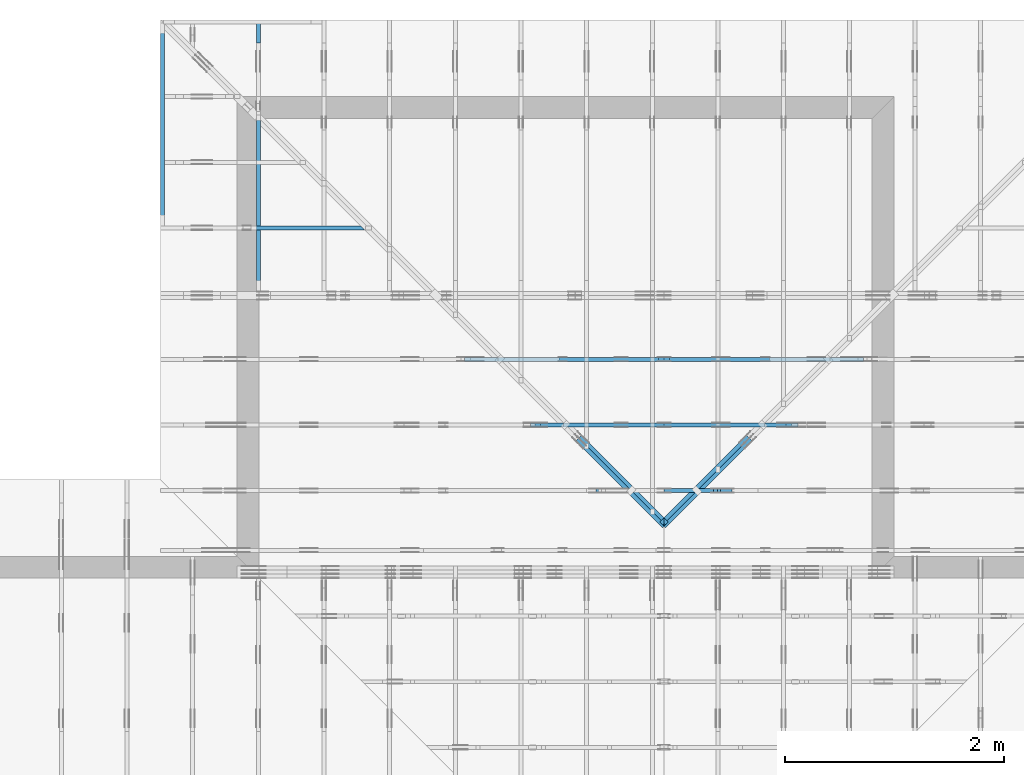
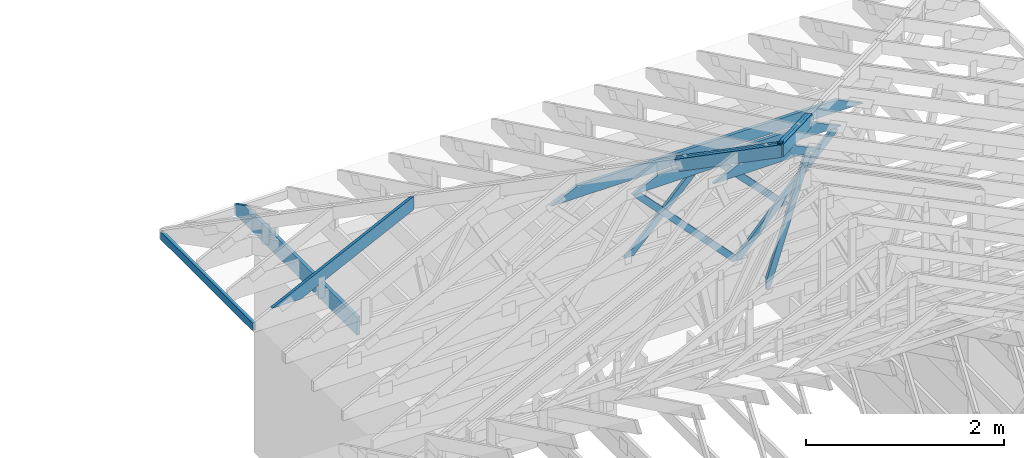
# One storey, part 25 of 159: 15 members, 8 elements without a shape of their own.
"""IFC2X3 building model written with IfcOpenShell, lengths in millimetres."""

from ifc_helpers import new_model, si_unit, frame, origin, origin_with_axes, origin_2d, place, context, project, spatial, faceted_brep, element, aggregate, save


model = new_model("IFC2X3")

# Units and contexts
model_context = context("Model", 3, precision=1e-05, world=origin())
plan_context = context("Plan", 2, precision=1e-05, world=origin_2d())
ifc_project = project(units=[si_unit("LENGTHUNIT", "METRE", prefix="MILLI"), si_unit("AREAUNIT", "SQUARE_METRE"), si_unit("VOLUMEUNIT", "CUBIC_METRE"), si_unit("SOLIDANGLEUNIT", "STERADIAN"), si_unit("PLANEANGLEUNIT", "RADIAN"), si_unit("MASSUNIT", "GRAM"), si_unit("TIMEUNIT", "SECOND"), si_unit("THERMODYNAMICTEMPERATUREUNIT", "DEGREE_CELSIUS"), si_unit("LUMINOUSINTENSITYUNIT", "LUMEN")], contexts=[model_context, plan_context])

# Site, building, storey
site_placement = place(None, origin_with_axes())
site = spatial("IfcSite", under=ifc_project, at=site_placement, CompositionType="ELEMENT")
building_placement = place(site_placement, origin_with_axes())
building = spatial("IfcBuilding", under=site, at=building_placement, Name="Plan 1", CompositionType="ELEMENT")
storey_placement = place(building_placement, origin_with_axes())
storey = spatial("IfcBuildingStorey", under=building, at=storey_placement, Name="Etasje 1", CompositionType="ELEMENT", Elevation=0.0)

# Assembly, members
assembly_1_placement = place(storey_placement, frame((19200.01266310149, 9617.999978540158, 1.1021457184401395e-15), z_axis=(1.2246063538223773e-16, 1.0, 6.123031769111886e-17), x_axis=(-1.0, 1.2246063538223773e-16, 0.0)))
assembly_1 = element("IfcElementAssembly", 1, at=assembly_1_placement, inside=storey, Name="V12 (104)", AssemblyPlace="FACTORY", PredefinedType="TRUSS")
member_1_placement = place(assembly_1_placement, frame((3978.554931640625, 1895.805857047475, -36.0), z_axis=(0.0, 0.0, 1.0), x_axis=(1.0, 0.0, 0.0)))
member_1 = element("IfcMember", 2, at=member_1_placement, Name="V12-O66", context=model_context, shape_type="Brep", body=[
    faceted_brep([(939.445068359375, 148.00005115565, 36.0), (303.445068359375, 148.00005115565, 36.0), (0.0, 5.115564999869093e-05, 36.0), (1242.889892578125, 5.115564999869093e-05, 36.0), (303.445068359375, 148.00005115565, 3.7160075874895624e-14), (939.445068359375, 148.00005115565, 1.1504503997799882e-13), (1242.889892578125, 5.115564999869093e-05, 1.5220508595527838e-13), (0.0, 5.115564999869093e-05, 0.0), (9.980311732828349e-05, 1.726732905965589e-14, 1.176335540281372e-30), (9.980311732924978e-05, 1.528612577229166e-14, 36.0), (303.44506835668295, 148.0000000000001, 36.0), (303.44506835668295, 148.0000000000001, 4.210503325783898e-30), (1242.8900369171897, -2.2830765544669794e-13, 1.397935027431582e-29), (1242.8900369171897, -2.2610336400981766e-13, 36.0), (9.980311733670533e-05, 2.2042731039505358e-15, 36.0), (9.980311733670533e-05, -1.833292974327144e-20, 1.1225311123894724e-36), (939.4450683634493, 148.0, -6.310887241768095e-30), (939.4450683634493, 148.0, 36.0), (1242.8900369171895, -5.684341886080802e-14, 36.0), (1242.8900369171895, -5.684341886080802e-14, -1.262177448353619e-29), (303.4450683566829, 147.99999999999997, -1.5777218104420236e-30), (303.4450683566829, 147.99999999999997, 36.0), (939.4450683634495, 147.99999999999994, 36.0), (939.4450683634495, 147.99999999999994, -3.1554436208840472e-30)], [[[0, 1, 2, 3]], [[4, 5, 6, 7]], [[8, 9, 10, 11]], [[12, 13, 14, 15]], [[16, 17, 18, 19]], [[20, 21, 22, 23]]]),
])
member_2_placement = place(assembly_1_placement, frame((4077.2969087031597, 1884.6815068738333, -36.00000000000001), z_axis=(0.0, 0.0, 1.0), x_axis=(0.30477671708606047, -0.9524238304044285, 0.0)))
member_2 = element("IfcMember", 3, at=member_2_placement, Name="V12-D25", context=model_context, shape_type="Brep", body=[
    faceted_brep([(1495.9083610694265, 72.99980213403342, 36.0), (11.680034532981153, 72.99980213403342, 36.0), (2.590980784589192e-06, 36.500175943107024, 36.0), (21.17387416001816, 3.316063794045476e-05, 36.0), (1589.2940390233093, 3.316063794045476e-05, 36.0), (1600.9740709653097, 36.500175943107024, 36.0), (11.680034532981153, 72.99980213403342, 1.4303444501953502e-15), (1495.9083610694265, 72.99980213403342, 1.8318988837016385e-13), (1600.9740709653097, 36.500175943107024, 1.9605630196089958e-13), (1589.2940390233093, 3.316063794045476e-05, 1.9462595782799738e-13), (21.17387416001816, 3.316063794045476e-05, 2.592966083139369e-15), (2.590980784589192e-06, 36.500175943107024, 3.1729315314396126e-22), (-1.7763568394002505e-15, 36.50000000000182, 0.0), (0.0, 36.50000000000182, 36.0), (11.680041824359703, 73.0, 36.0), (11.6800418243597, 73.0, 1.9721522630525295e-31), (21.173904436015164, -1.7763568394002505e-15, 1.9721522630525295e-31), (21.173904436015164, 0.0, 36.0), (1.0658141036401503e-14, 36.50000000000182, 36.0), (8.881784197001252e-15, 36.50000000000182, -5.9164567891575885e-31), (1589.2940291414986, -3.042195973562896e-13, 7.431611212193568e-29), (1589.2940291414986, -3.020153059194093e-13, 36.0), (21.173904436015164, -1.3965825678748254e-14, 36.0), (21.173904436015164, -1.6170117115628533e-14, 9.901014080925337e-31), (1600.9740709657392, 36.50000000004093, 0.0), (1600.9740709657392, 36.50000000004093, 36.0), (1589.2940291414986, 9.094947017729282e-13, 36.0), (1589.2940291414986, 9.094947017729282e-13, 0.0), (1495.9084378416383, 73.00000000000091, 0.0), (1495.9084378416383, 73.00000000000091, 36.0), (1600.9740709657394, 36.50000000004087, 36.0), (1600.9740709657394, 36.50000000004087, 0.0), (11.680041824359705, 73.0, 0.0), (11.680041824359705, 73.0, 36.0), (1495.9084378416383, 73.00000000000122, 36.0), (1495.9084378416383, 73.00000000000122, 1.8932661725304283e-29)], [[[0, 1, 2, 3, 4, 5]], [[6, 7, 8, 9, 10, 11]], [[12, 13, 14, 15]], [[16, 17, 18, 19]], [[20, 21, 22, 23]], [[24, 25, 26, 27]], [[28, 29, 30, 31]], [[32, 33, 34, 35]]]),
])
aggregate(assembly_1, [member_1, member_2])

assembly_2_placement = place(storey_placement, frame((19200.01266310149, 10817.999978540158, 1.1021457184401395e-15), z_axis=(1.2246063538223773e-16, 1.0, 6.123031769111886e-17), x_axis=(-1.0, 1.2246063538223773e-16, 0.0)))
assembly_2 = element("IfcElementAssembly", 4, at=assembly_2_placement, inside=storey, Name="V10 (59)", AssemblyPlace="FACTORY", PredefinedType="TRUSS")
member_3_placement = place(assembly_2_placement, frame((2778.554931640625, 1310.5267212208346, -36.0), z_axis=(0.0, 0.0, 1.0), x_axis=(1.0, 0.0, 0.0)))
member_3 = element("IfcMember", 5, at=member_3_placement, Name="V10-O26", context=model_context, shape_type="Brep", body=[
    faceted_brep([(3339.445068359375, 148.0000121776029, 36.0), (303.445068359375, 148.0000121776029, 36.0), (0.0, 1.2177602911833674e-05, 36.0), (3642.889892578125, 1.2177602911833674e-05, 36.0), (303.445068359375, 148.0000121776029, 3.7160075874895624e-14), (3339.445068359375, 148.0000121776029, 4.0895056489536936e-13), (3642.889892578125, 1.2177602911833674e-05, 4.461106108726489e-13), (0.0, 1.2177602911833674e-05, 0.0), (3.921889583978464e-05, -8.165699155260678e-15, -5.562879373176012e-31), (3.9218895840750935e-05, -1.0146902442624908e-14, 36.0), (303.4450077725487, 147.99999999999994, 36.0), (303.4450077725487, 147.99999999999994, -4.544424296776122e-30), (3642.8900974970893, 5.801906707589623e-12, 9.025660530362037e-29), (3642.8900974970893, 5.804110999026503e-12, 36.0), (3.921889583580196e-05, 2.2042755674339286e-15, 36.0), (3.921889583580196e-05, -1.5869446350328157e-20, 9.716912416127598e-37), (3339.445128943349, 148.00000000000637, -3.7865323450608567e-29), (3339.445128943349, 148.00000000000637, 36.0), (3642.8900974970884, 6.59383658785373e-12, 36.0), (3642.8900974970884, 6.59383658785373e-12, -5.048709793414476e-29), (303.4450077725487, 147.99999999999997, -1.5777218104420236e-30), (303.4450077725487, 147.99999999999997, 36.0), (3339.445128943349, 148.00000000000722, 36.0), (3339.445128943349, 148.00000000000722, -3.1554436208840472e-30)], [[[0, 1, 2, 3]], [[4, 5, 6, 7]], [[8, 9, 10, 11]], [[12, 13, 14, 15]], [[16, 17, 18, 19]], [[20, 21, 22, 23]]]),
])
member_4_placement = place(assembly_2_placement, frame((4573.791990100676, 1335.9312526508254, -36.0), z_axis=(0.0, 0.0, 1.0), x_axis=(-0.6960143877008778, -0.7180278351939932, 0.0)))
member_4 = element("IfcMember", 6, at=member_4_placement, Name="V10-D36", context=model_context, shape_type="Brep", body=[
    faceted_brep([(1273.1014038603507, 72.99993872595087, 36.0), (37.65438940421609, 72.99993872595087, 36.0), (0.0, 36.49999152504006, 36.0), (35.380844658386195, 0.0001263695025954803, 36.0), (1343.8632631025112, 0.0001263695025954803, 36.0), (37.65438940421609, 72.99993872595087, 4.611180451370502e-15), (1273.1014038603507, 72.99993872595087, 1.559048068227574e-13), (1343.8632631025112, 0.0001263695025954803, 1.6457034906638082e-13), (35.380844658386195, 0.0001263695025954803, 4.332760717226225e-15), (0.0, 36.49999152504006, 0.0), (8.74465331790475e-06, 36.50000000000091, -1.9721522630525295e-31), (8.74465331790475e-06, 36.50000000000091, 36.0), (37.65442573317342, 73.00000000000091, 36.0), (37.65442573317342, 73.00000000000091, 1.9721522630525295e-31), (35.38098411341254, 4.618527782440651e-13, -7.888609052210118e-31), (35.38098411341254, 4.618527782440651e-13, 36.0), (8.744653314352036e-06, 36.50000000000091, 36.0), (8.744653314352036e-06, 36.50000000000091, 0.0), (1343.8632952015714, 2.2018805853570262e-13, -1.348218477593175e-29), (1343.8632952015714, 2.223923499725829e-13, 36.0), (35.380984113412524, 4.627487127759951e-13, 36.0), (35.380984113412524, 4.605444213391148e-13, -3.549564654936033e-31), (1273.101344464069, 72.99999999999943, -1.262177448353619e-29), (1273.101344464069, 72.99999999999943, 36.0), (1343.8632952015714, -1.1368683772161603e-13, 36.0), (1343.8632952015714, -1.1368683772161603e-13, -1.262177448353619e-29), (37.65442573317341, 73.00000000000091, 0.0), (37.65442573317341, 73.00000000000091, 36.0), (1273.101344464069, 72.99999999999946, 36.0), (1273.101344464069, 72.99999999999946, -5.5220263365470826e-30)], [[[0, 1, 2, 3, 4]], [[5, 6, 7, 8, 9]], [[10, 11, 12, 13]], [[14, 15, 16, 17]], [[18, 19, 20, 21]], [[22, 23, 24, 25]], [[26, 27, 28, 29]]]),
])
member_5_placement = place(assembly_2_placement, frame((4573.791896053719, 1285.1221229822427, -36.0), z_axis=(0.0, 0.0, 1.0), x_axis=(0.6960143877031446, -0.7180278351917958, 0.0)))
member_5 = element("IfcMember", 7, at=member_5_placement, Name="V10-D36", context=model_context, shape_type="Brep", body=[
    faceted_brep([(1343.8632631026262, 73.00008091038126, 36.0), (35.3808446585017, 73.00008091038126, 36.0), (0.0, 36.500122504694446, 36.0), (37.65438940410104, 0.00014924330935173202, 36.0), (1273.101233934848, 0.00014924330935173202, 36.0), (35.3808446585017, 73.00008091038126, 4.33276071724037e-15), (1343.8632631026262, 73.00008091038126, 1.645703490663949e-13), (1273.101233934848, 0.00014924330935173202, 1.5590478601357238e-13), (37.65438940410104, 0.00014924330935173202, 4.611180451356413e-15), (0.0, 36.500122504694446, 0.0), (8.743057154703138e-06, 36.50011402808651, 0.0), (8.743057154703138e-06, 36.50011402808651, 36.0), (35.380984112040096, 73.00011402808651, 36.0), (35.380984112040096, 73.00011402808651, 7.888609052210118e-31), (37.65442573157679, 0.00011402808649307872, 7.888609052210118e-31), (37.65442573157679, 0.00011402808649307872, 36.0), (8.743057158255851e-06, 36.50011402808651, 36.0), (8.743057158255851e-06, 36.50011402808651, -5.9164567891575885e-31), (1273.1013444665236, 0.00011402808406028452, 3.801853117768457e-29), (1273.1013444665236, 0.00011402808406248881, 36.0), (37.654425731576794, 0.00011402808648402381, 36.0), (37.654425731576794, 0.00011402808648181952, 1.1244722536237163e-30), (1343.863295204505, 73.00011402808457, 6.310887241768095e-30), (1343.863295204505, 73.00011402808457, 36.0), (1273.1013444665236, 0.00011402808468119474, 36.0), (1273.1013444665236, 0.00011402808468119474, 6.310887241768095e-30), (35.380984112040096, 73.0001140280865, 0.0), (35.380984112040096, 73.0001140280865, 36.0), (1343.863295204505, 73.00011402808497, 36.0), (1343.863295204505, 73.00011402808497, 1.735493991486226e-29)], [[[0, 1, 2, 3, 4]], [[5, 6, 7, 8, 9]], [[10, 11, 12, 13]], [[14, 15, 16, 17]], [[18, 19, 20, 21]], [[22, 23, 24, 25]], [[26, 27, 28, 29]]]),
])
aggregate(assembly_2, [member_3, member_4, member_5])

assembly_3_placement = place(storey_placement, frame((19200.01266310149, 10217.999978540158, 1.1021457184401395e-15), z_axis=(1.2246063538223773e-16, 1.0, 6.123031769111886e-17), x_axis=(-1.0, 1.2246063538223773e-16, 0.0)))
assembly_3 = element("IfcElementAssembly", 8, at=assembly_3_placement, inside=storey, Name="V11 (60)", AssemblyPlace="FACTORY", PredefinedType="TRUSS")
member_6_placement = place(assembly_3_placement, frame((3378.554931640625, 1603.166259765625, -36.0), z_axis=(0.0, 0.0, 1.0), x_axis=(1.0, 0.0, 0.0)))
member_6 = element("IfcMember", 9, at=member_6_placement, Name="V11-O48", context=model_context, shape_type="Brep", body=[
    faceted_brep([(2139.445068359375, 148.0, 36.0), (303.445068359375, 148.0, 36.0), (0.0, 0.0, 36.0), (2442.889892578125, 0.0, 36.0), (303.445068359375, 148.0, 3.7160075874895624e-14), (2139.445068359375, 148.0, 2.619978024366841e-13), (2442.889892578125, 0.0, 2.9915784841396365e-13), (0.0, 0.0, 0.0), (2.0665524052797e-05, 5.545072799783553e-06, 1.2532157626430866e-30), (2.06655240537633e-05, 5.545072797802349e-06, 36.0), (303.44498921929335, 148.0000055450728, 36.0), (303.44498921929335, 148.0000055450728, 3.840659239655909e-31), (2442.8901160541864, 5.5450658234841165e-06, -1.9474548352191542e-29), (2442.8901160541864, 5.545065825688408e-06, 36.0), (2.0665524061769247e-05, 5.545072783592011e-06, 36.0), (2.0665524061769247e-05, 5.54507278138772e-06, -1.88079096131566e-37), (2139.4451475006645, 148.0000055450654, 0.0), (2139.4451475006645, 148.0000055450654, 36.0), (2442.8901160541864, 5.545065391743265e-06, 36.0), (2442.8901160541864, 5.545065391743265e-06, 0.0), (303.4449892192933, 148.00000554507275, -3.1554436208840472e-30), (303.4449892192933, 148.00000554507275, 36.0), (2139.4451475006645, 148.00000554506528, 36.0), (2139.4451475006645, 148.0000055450653, -1.262177448353619e-29)], [[[0, 1, 2, 3]], [[4, 5, 6, 7]], [[8, 9, 10, 11]], [[12, 13, 14, 15]], [[16, 17, 18, 19]], [[20, 21, 22, 23]]]),
])
member_7_placement = place(assembly_3_placement, frame((3409.999451517191, 1578.1073944721513, -36.0), z_axis=(0.0, 0.0, 1.0), x_axis=(0.6865453247740573, -0.7270870078820583, 0.0)))
member_7 = element("IfcMember", 10, at=member_7_placement, Name="V11-D22", context=model_context, shape_type="Brep", body=[
    faceted_brep([(1656.249372918049, 72.99989747866357, 36.0), (34.46487700814578, 72.99989747866357, 36.0), (0.0, 36.4999431053152, 36.0), (9.319068295096486, 6.416159203581628e-05, 36.0), (1660.196707283959, 6.416159203581628e-05, 36.0), (1694.6614166785005, 36.4999431053152, 36.0), (34.46487700814578, 72.99989747866357, 4.220590736788208e-15), (1656.249372918049, 72.99989747866357, 2.0282535055897706e-13), (1694.6614166785005, 36.4999431053152, 2.0752931384421227e-13), (1660.196707283959, 6.416159203581628e-05, 2.0330874363349257e-13), (9.319068295096486, 6.416159203581628e-05, 1.1412190245879825e-15), (0.0, 36.4999431053152, 0.0), (4.6095872892948364e-05, 36.500000000005016, 7.888609052210118e-31), (4.6095872892948364e-05, 36.500000000005016, 36.0), (34.464840656354426, 73.00000000000094, 36.0), (34.464840656354426, 73.00000000000094, 2.1693674893577825e-30), (9.31899149349306, 9.094947017729282e-13, 0.0), (9.318991493493062, 9.099387909827783e-13, 36.0), (4.609587291781736e-05, 36.50000000000501, 36.0), (4.6095872916041e-05, 36.50000000000501, -7.888609052210118e-31), (1660.1966221186528, -8.648852298636358e-13, 5.295719739090679e-29), (1660.1966221186528, -8.626809384267556e-13, 36.0), (9.318991493493058, 9.068442320372063e-13, 36.0), (9.318991493493058, 9.04639940600326e-13, 2.9725856891294758e-31), (1694.661416679085, 36.50000000005332, 1.262177448353619e-29), (1694.661416679085, 36.50000000005332, 36.0), (1660.196622118653, -2.2737367544323206e-13, 36.0), (1660.196622118653, -2.2737367544323206e-13, 2.524354896707238e-29), (1656.2494715220669, 73.0, 5.532134216663918e-30), (1656.2494715220669, 73.0, 36.0), (1694.661416679085, 36.50000000005366, 36.0), (1694.661416679085, 36.50000000005366, 5.205570489469399e-30), (34.464840656354454, 73.00000000000091, 0.0), (34.464840656354454, 73.00000000000091, 36.0), (1656.2494715220666, 73.00000000000009, 36.0), (1656.2494715220666, 73.00000000000009, 5.5220263365470826e-30)], [[[0, 1, 2, 3, 4, 5]], [[6, 7, 8, 9, 10, 11]], [[12, 13, 14, 15]], [[16, 17, 18, 19]], [[20, 21, 22, 23]], [[24, 25, 26, 27]], [[28, 29, 30, 31]], [[32, 33, 34, 35]]]),
])
member_8_placement = place(assembly_3_placement, frame((5751.8733332354495, 1628.392158160853, -36.0), z_axis=(0.0, 0.0, 1.0), x_axis=(-0.6911183884224101, -0.7227415673561406, 0.0)))
member_8 = element("IfcMember", 11, at=member_8_placement, Name="V11-D21", context=model_context, shape_type="Brep", body=[
    faceted_brep([(1669.9475924469943, 72.99996446088244, 36.0), (9.07408193396077, 72.99996446088244, 36.0), (4.36968084613909e-05, 36.50006603255042, 36.0), (34.90287215274202, 0.0002052764411928365, 36.0), (1666.4385731030916, 0.0002052764411928365, 36.0), (1704.8504209029284, 36.50006603255042, 36.0), (9.07408193396077, 72.99996446088244, 1.1112178391433203e-15), (1669.9475924469943, 72.99996446088244, 2.0450284322609711e-13), (1704.8504209029284, 36.50006603255042, 2.0877706577544804e-13), (1666.4385731030916, 0.0002052764411928365, 2.040731264876742e-13), (34.90287215274202, 0.0002052764411928365, 4.2742279004897994e-15), (4.36968084613909e-05, 36.50006603255042, 5.3511389283578715e-21), (3.552713678800501e-15, 36.500103705449874, -2.9582283945787943e-31), (5.329070518200751e-15, 36.500103705449874, 36.0), (9.07407071152558, 73.00010370544713, 36.0), (9.074070711525577, 73.00010370544713, -7.888609052210118e-31), (34.90296160728576, 0.00010370544623583555, 0.0), (34.90296160728576, 0.00010370544623583555, 36.0), (0.0, 36.500103705449874, 36.0), (0.0, 36.500103705449874, 1.9721522630525295e-31), (1666.4384757452126, 0.00010370544591026933, 7.562317248715648e-29), (1666.4384757452126, 0.00010370544591247362, 36.0), (34.90296160728576, 0.00010370544621217193, 36.0), (34.90296160728576, 0.00010370544620996764, 1.5838998325917533e-30), (1704.8504209022838, 36.500103705447486, -3.7865323450608567e-29), (1704.8504209022838, 36.500103705447486, 36.0), (1666.4384757452121, 0.00010370544737270393, 36.0), (1666.4384757452121, 0.00010370544737270393, -3.7865323450608567e-29), (1669.9474592950041, 73.00010370544624, 2.802596928649634e-45), (1669.9474592950041, 73.00010370544624, 36.0), (1704.850420902284, 36.50010370544726, 36.0), (1704.850420902284, 36.50010370544726, 2.802596928649634e-45), (9.074070711525565, 73.00010370544715, 0.0), (9.074070711525565, 73.00010370544715, 36.0), (1669.9474592950037, 73.00010370544629, 36.0), (1669.9474592950037, 73.0001037054463, 4.733165431326071e-30)], [[[0, 1, 2, 3, 4, 5]], [[6, 7, 8, 9, 10, 11]], [[12, 13, 14, 15]], [[16, 17, 18, 19]], [[20, 21, 22, 23]], [[24, 25, 26, 27]], [[28, 29, 30, 31]], [[32, 33, 34, 35]]]),
])
aggregate(assembly_3, [member_6, member_7, member_8])

assembly_4_placement = place(storey_placement, frame((19174.556818978774, 13925.455822662876, 2.204291436880279e-15), z_axis=(-0.7071067811865465, 0.7071067811865486, 6.123031769111886e-17), x_axis=(-0.7071067811865486, -0.7071067811865465, 0.0)))
assembly_4 = element("IfcElementAssembly", 12, at=assembly_4_placement, inside=storey, Name="GR3 (58)", AssemblyPlace="FACTORY", PredefinedType="TRUSS")
member_9_placement = place(assembly_4_placement, frame((5450.934542923971, 1837.150625319896, -36.0), z_axis=(0.0, 0.0, 1.0), x_axis=(0.9453579955214153, 0.326034139782526, 0.0)))
member_9 = element("IfcMember", 13, at=member_9_placement, Name="GR3-O67", context=model_context, shape_type="Brep", body=[
    faceted_brep([(1185.4777155042157, 148.0000088388881, 36.0), (0.00017870213559945114, 148.0000088388881, 36.0), (2.897159538406413e-05, 0.0, 36.0), (1134.4356222344104, 0.0, 36.0), (0.00017870213559945114, 148.0000088388881, 2.188397706967159e-20), (1185.4777155042157, 148.0000088388881, 1.4517435427212991e-13), (1134.4356222344104, 0.0, 1.389237070990701e-13), (2.897159538406413e-05, 0.0, 3.547879978769599e-21), (1.3036876641688255e-20, 6.703622511849971e-05, -7.982520984704973e-37), (2.2043044737569208e-15, 6.703622511849971e-05, 36.0), (9.404813213196578e-13, 148.00006703622512, 36.0), (9.382770298827775e-13, 148.00006703622512, -1.7623510940560896e-30), (1134.4357068212394, 6.703667832170513e-05, 2.4937705273372609e-29), (1134.4357068212394, 6.703667832390943e-05, 36.0), (-8.806060447957977e-28, 6.7036225120704e-05, 36.0), (0.0, 6.703622511849971e-05, 0.0), (1185.477801896506, 148.00006703592442, -1.0999619829670673e-29), (1185.477801896506, 148.00006703592442, 36.0), (1134.4357068212391, 6.703667878582564e-05, 36.0), (1134.4357068212391, 6.703667878582564e-05, -1.148204047136317e-29), (9.094947017729282e-13, 148.00006703622512, 0.0), (9.094947017729282e-13, 148.00006703622512, 36.0), (1185.4778018965062, 148.00006703592416, 36.0), (1185.4778018965062, 148.00006703592416, -7.888609052210118e-30)], [[[0, 1, 2, 3]], [[4, 5, 6, 7]], [[8, 9, 10, 11]], [[12, 13, 14, 15]], [[16, 17, 18, 19]], [[20, 21, 22, 23]]]),
])
member_10_placement = place(assembly_4_placement, frame((5450.934542923971, 1837.150625319896, -72.0), z_axis=(0.0, 0.0, 1.0), x_axis=(0.9453579955214153, 0.326034139782526, 0.0)))
member_10 = element("IfcMember", 14, at=member_10_placement, Name="GR3-O67", context=model_context, shape_type="Brep", body=[
    faceted_brep([(1185.4777155042157, 148.0000088388881, 36.0), (0.00017870213559945114, 148.0000088388881, 36.0), (2.897159538406413e-05, 0.0, 36.0), (1134.4356222344104, 0.0, 36.0), (0.00017870213559945114, 148.0000088388881, 2.188397706967159e-20), (1185.4777155042157, 148.0000088388881, 1.4517435427212991e-13), (1134.4356222344104, 0.0, 1.389237070990701e-13), (2.897159538406413e-05, 0.0, 3.547879978769599e-21), (1.3036876641688255e-20, 6.703622511849971e-05, -7.982520984704973e-37), (2.2043044737569208e-15, 6.703622511849971e-05, 36.0), (9.404813213196578e-13, 148.00006703622512, 36.0), (9.382770298827775e-13, 148.00006703622512, -1.7623510940560896e-30), (1134.4357068212394, 6.703667832170513e-05, 2.4937705273372609e-29), (1134.4357068212394, 6.703667832390943e-05, 36.0), (-8.806060447957977e-28, 6.7036225120704e-05, 36.0), (0.0, 6.703622511849971e-05, 0.0), (1185.477801896506, 148.00006703592442, -1.0999619829670673e-29), (1185.477801896506, 148.00006703592442, 36.0), (1134.4357068212391, 6.703667878582564e-05, 36.0), (1134.4357068212391, 6.703667878582564e-05, -1.148204047136317e-29), (9.094947017729282e-13, 148.00006703622512, 0.0), (9.094947017729282e-13, 148.00006703622512, 36.0), (1185.4778018965062, 148.00006703592416, 36.0), (1185.4778018965062, 148.00006703592416, -7.888609052210118e-30)], [[[0, 1, 2, 3]], [[4, 5, 6, 7]], [[8, 9, 10, 11]], [[12, 13, 14, 15]], [[16, 17, 18, 19]], [[20, 21, 22, 23]]]),
])
aggregate(assembly_4, [member_9, member_10])

assembly_5_placement = place(storey_placement, frame((9974.55681897877, 13874.544134417441, 2.204291436880279e-15), z_axis=(-0.7071067811865477, -0.7071067811865474, 6.123031769111886e-17), x_axis=(0.7071067811865474, -0.7071067811865477, 0.0)))
assembly_5 = element("IfcElementAssembly", 15, at=assembly_5_placement, inside=storey, Name="GR2 (61)", AssemblyPlace="FACTORY", PredefinedType="TRUSS")
member_11_placement = place(assembly_5_placement, frame((5450.934542922306, 1837.1506253193215, -36.0), z_axis=(0.0, 0.0, 1.0), x_axis=(0.9453579955214151, 0.3260341397825261, 0.0)))
member_11 = element("IfcMember", 16, at=member_11_placement, Name="GR2-O67", context=model_context, shape_type="Brep", body=[
    faceted_brep([(1185.4777155059774, 148.00000883888765, 36.0), (0.00017870389638119377, 148.00000883888765, 36.0), (2.8973356165806763e-05, 0.0, 36.0), (1134.4356222361712, 0.0, 36.0), (0.00017870389638119377, 148.00000883888765, 2.1884192696122562e-20), (1185.4777155059774, 148.00000883888765, 1.4517435427234564e-13), (1134.4356222361712, 0.0, 1.3892370709928573e-13), (2.8973356165806763e-05, 0.0, 3.548095605220571e-21), (1.303687703854692e-20, 6.703622671011544e-05, -7.982521227702798e-37), (2.2043044737573176e-15, 6.703622671011544e-05, 36.0), (9.404813213196626e-13, 148.0000670362274, 36.0), (9.382770298827823e-13, 148.0000670362274, -1.7623510940563814e-30), (1134.4357068229874, 6.703668293606481e-05, -7.002080177000753e-30), (1134.4357068229874, 6.70366829382691e-05, 36.0), (-8.86479360754201e-28, 6.703622671231973e-05, 36.0), (0.0, 6.703622671011544e-05, 0.0), (1185.477801898254, 148.0000670359284, -2.3621394313205094e-29), (1185.477801898254, 148.0000670359284, 36.0), (1134.4357068229872, 6.703668282170838e-05, 36.0), (1134.4357068229872, 6.703668282170838e-05, -1.1482040471361401e-29), (9.094947017729282e-13, 148.0000670362274, 0.0), (9.094947017729282e-13, 148.0000670362274, 36.0), (1185.4778018982543, 148.00006703592828, 36.0), (1185.4778018982543, 148.00006703592828, -6.310887241768095e-30)], [[[0, 1, 2, 3]], [[4, 5, 6, 7]], [[8, 9, 10, 11]], [[12, 13, 14, 15]], [[16, 17, 18, 19]], [[20, 21, 22, 23]]]),
])
member_12_placement = place(assembly_5_placement, frame((5450.934542922306, 1837.1506253193215, -72.0), z_axis=(0.0, 0.0, 1.0), x_axis=(0.9453579955214151, 0.3260341397825261, 0.0)))
member_12 = element("IfcMember", 17, at=member_12_placement, Name="GR2-O67", context=model_context, shape_type="Brep", body=[
    faceted_brep([(1185.4777155059774, 148.00000883888765, 36.0), (0.00017870389638119377, 148.00000883888765, 36.0), (2.8973356165806763e-05, 0.0, 36.0), (1134.4356222361712, 0.0, 36.0), (0.00017870389638119377, 148.00000883888765, 2.1884192696122562e-20), (1185.4777155059774, 148.00000883888765, 1.4517435427234564e-13), (1134.4356222361712, 0.0, 1.3892370709928573e-13), (2.8973356165806763e-05, 0.0, 3.548095605220571e-21), (1.303687703854692e-20, 6.703622671011544e-05, -7.982521227702798e-37), (2.2043044737573176e-15, 6.703622671011544e-05, 36.0), (9.404813213196626e-13, 148.0000670362274, 36.0), (9.382770298827823e-13, 148.0000670362274, -1.7623510940563814e-30), (1134.4357068229874, 6.703668293606481e-05, -7.002080177000753e-30), (1134.4357068229874, 6.70366829382691e-05, 36.0), (-8.86479360754201e-28, 6.703622671231973e-05, 36.0), (0.0, 6.703622671011544e-05, 0.0), (1185.477801898254, 148.0000670359284, -2.3621394313205094e-29), (1185.477801898254, 148.0000670359284, 36.0), (1134.4357068229872, 6.703668282170838e-05, 36.0), (1134.4357068229872, 6.703668282170838e-05, -1.1482040471361401e-29), (9.094947017729282e-13, 148.0000670362274, 0.0), (9.094947017729282e-13, 148.0000670362274, 36.0), (1185.4778018982543, 148.00006703592828, 36.0), (1185.4778018982543, 148.00006703592828, -6.310887241768095e-30)], [[[0, 1, 2, 3]], [[4, 5, 6, 7]], [[8, 9, 10, 11]], [[12, 13, 14, 15]], [[16, 17, 18, 19]], [[20, 21, 22, 23]]]),
])
aggregate(assembly_5, [member_11, member_12])

# Assembly, member
assembly_6_placement = place(storey_placement, frame((10875.022261404756, 13899.999978540158, 1.1021457184401395e-15), z_axis=(-1.0, 1.836909530733566e-16, 6.123031769111886e-17), x_axis=(-1.836909530733566e-16, -1.0, 0.0)))
assembly_6 = element("IfcElementAssembly", 18, at=assembly_6_placement, inside=storey, Name="S30 (72)", AssemblyPlace="FACTORY", PredefinedType="TRUSS")
member_13_placement = place(assembly_6_placement, frame((2482.0, 223.00000000093104, -36.0), z_axis=(0.0, 0.0, 1.0), x_axis=(-1.0, 1.2246063538223773e-16, 0.0)))
member_13 = element("IfcMember", 19, at=member_13_placement, Name="S30-U12", context=model_context, shape_type="Brep", body=[
    faceted_brep([(2482.0, 223.00000000093135, 36.0), (0.0, 223.00000000093135, 36.0), (0.0, 9.310383575211745e-10, 36.0), (2270.8187103271484, 9.310383575211745e-10, 36.0), (2482.000000000002, 103.00000000093135, 36.0), (0.0, 223.00000000093135, 0.0), (2482.0, 223.00000000093135, 3.0394729701871404e-13), (2482.000000000002, 103.00000000093135, 3.0394729701871424e-13), (2270.8187103271484, 9.310383575211745e-10, 2.7808590210453623e-13), (0.0, 9.310383575211745e-10, 0.0), (1.1401554882727804e-25, 9.310383575211745e-10, -6.981208276421509e-42), (2.2042914369942947e-15, 9.310383575211745e-10, 36.0), (2.9513013127233304e-14, 223.00000000093104, 36.0), (2.730872169035303e-14, 223.00000000093104, -1.6721217048386645e-30), (2270.8187043163925, 8.339391172955722e-13, -5.106235708706442e-29), (2270.8187043163925, 8.361434087324525e-13, 36.0), (9.029525915557911e-28, 9.310405618126114e-10, 36.0), (0.0, 9.310383575211745e-10, 0.0), (2482.000000000001, 103.00000000074351, -9.396085556655556e-29), (2482.000000000001, 103.00000000074351, 36.0), (2270.818704316392, 1.2505552149377763e-12, 36.0), (2270.818704316392, 1.2505552149377763e-12, -8.206310969932178e-29), (2482.000000000003, 223.00000000093135, 2.0194839173657902e-28), (2482.000000000003, 223.00000000093135, 36.0), (2482.000000000003, 103.00000000074218, 36.0), (2482.000000000003, 103.00000000074218, 1.0097419586828951e-28), (0.0, 223.00000000093104, 0.0), (0.0, 223.00000000093104, 36.0), (2482.0, 223.00000000093144, 36.0), (2482.0, 223.00000000093144, 4.733165431326071e-30)], [[[0, 1, 2, 3, 4]], [[5, 6, 7, 8, 9]], [[10, 11, 12, 13]], [[14, 15, 16, 17]], [[18, 19, 20, 21]], [[22, 23, 24, 25]], [[26, 27, 28, 29]]]),
])
aggregate(assembly_6, [member_13])

assembly_7_placement = place(storey_placement, frame((10000.012663101486, 11981.999978540158, 1.1021457184401395e-15), z_axis=(0.0, -1.0, 6.123031769111886e-17), x_axis=(1.0, 0.0, 0.0)))
assembly_7 = element("IfcElementAssembly", 20, at=assembly_7_placement, inside=storey, Name="S26 (76)", AssemblyPlace="FACTORY", PredefinedType="TRUSS")
member_14_placement = place(assembly_7_placement, frame((276.0602225679677, 89.97847976120347, -36.000000217573124), z_axis=(0.0, 0.0, 1.0), x_axis=(0.8987940462991671, 0.4383711467890776, 0.0)))
member_14 = element("IfcMember", 21, at=member_14_placement, Name="S26-O59", context=model_context, shape_type="Brep", body=[
    faceted_brep([(1842.3653633318013, 147.99999481907014, 36.00000324775567), (1770.180939380702, 2.3725874598312657e-09, 36.00000021757285), (1730.1272694381605, 3.23562233006669e-07, -2.2737367544323206e-13), (1802.31169338926, 147.99999514025978, 3.0301824835987645e-06), (6.0419684473345114e-06, 147.99999999997732, 2.1757311685632885e-07), (6.0419684473345114e-06, 147.9999999999772, 36.00000021757312), (1842.3653624872811, 147.9999999999771, 36.00000021757312), (1802.311693511451, 147.9999999999772, 2.1757311685632885e-07), (4.7122372450303374e-05, 148.00000000103617, 2.1757311685633462e-07), (1802.3116926301852, 148.00000000103617, 2.175733375685639e-07), (1730.1272672761813, 0.0, 2.1757332872881328e-07), (303.44499341143506, 0.0, 2.1757315401639556e-07), (303.44497171313134, 1.7039525346262963e-09, 2.1757311685632885e-07), (303.44497171313134, 1.7039525346262963e-09, 36.00000021757312), (1.4210854715202004e-14, 148.0000015426442, 36.00000021757312), (1.4210854715202004e-14, 148.0000015426442, 2.1757311685632885e-07), (1770.180938499416, 2.3540460099976206e-09, 36.00000021757312), (303.44501854702327, 2.354315436116664e-09, 36.00000021757312), (303.44501854702327, 2.3544331359118865e-09, 2.1757311685632885e-07), (1730.127269523586, 2.3541710672894718e-09, 2.1757311685632885e-07), (1842.3653647347057, 148.00000000237276, 36.00000021757312), (3.117757671589061e-05, 148.00000000237276, 36.00000021757312), (303.4449774666394, 1.7039667454810115e-09, 36.00000021757312), (1770.1809393807018, 1.7039667454810115e-09, 36.00000021757312)], [[[0, 1, 2, 3]], [[4, 5, 6, 7]], [[8, 9, 10, 11]], [[12, 13, 14, 15]], [[16, 17, 18, 19]], [[20, 21, 22, 23]]]),
])
aggregate(assembly_7, [member_14])

assembly_8_placement = place(storey_placement, frame((10000.012663101486, 13874.544134417441, 0.0), z_axis=(-1.0, 2.8530127750298756e-12, 6.123031769111886e-17), x_axis=(-2.8530127750298756e-12, -1.0, 0.0)))
assembly_8 = element("IfcElementAssembly", 22, at=assembly_8_placement, inside=storey, Name="uu5 (80)", AssemblyPlace="FACTORY", PredefinedType="TRUSS")
member_15_placement = place(assembly_8_placement, frame((1856.544189453125, 98.0, -36.0), z_axis=(0.0, 0.0, 1.0), x_axis=(-1.0, 1.2246063538223773e-16, 0.0)))
member_15 = element("IfcMember", 23, at=member_15_placement, Name="uu5-U48", context=model_context, shape_type="Brep", body=[
    faceted_brep([(1856.544189453125, 98.00000000000023, 36.0), (0.0, 98.00000000000023, 36.0), (0.0, 0.0, 36.0), (1856.544189453125, 0.0, 36.0), (0.0, 98.00000000000023, 0.0), (1856.544189453125, 98.00000000000023, 2.2735358105563122e-13), (1856.544189453125, 0.0, 2.2735358105563122e-13), (0.0, 0.0, 0.0), (3.357584682817105e-05, 0.0, 0.0), (3.3575846830375343e-05, -2.6993892992798474e-31, 36.0), (3.3575846842376486e-05, 98.0, 36.0), (3.3575846840172194e-05, 98.0, -7.348336802244504e-31), (1856.544189453125, -3.4103037569552983e-13, 3.480356062814536e-29), (1856.544189453125, -3.3882608425864955e-13, 36.0), (3.357584682817105e-05, 2.2042811572179548e-15, 36.0), (3.357584682817105e-05, -1.0279662324207141e-20, 6.294269898686286e-37), (1856.544189453125, 98.00000000000023, 0.0), (1856.544189453125, 98.00000000000023, 36.0), (1856.544189453125, 2.2737367544323206e-13, 36.0), (1856.544189453125, 2.2737367544323206e-13, 0.0), (3.357584682817105e-05, 98.0, 0.0), (3.357584682817105e-05, 98.0, 36.0), (1856.544189453125, 98.0000000000003, 36.0), (1856.544189453125, 98.0000000000003, 3.944304526105059e-30)], [[[0, 1, 2, 3]], [[4, 5, 6, 7]], [[8, 9, 10, 11]], [[12, 13, 14, 15]], [[16, 17, 18, 19]], [[20, 21, 22, 23]]]),
])
aggregate(assembly_8, [member_15])

save(model, "model.ifc")
